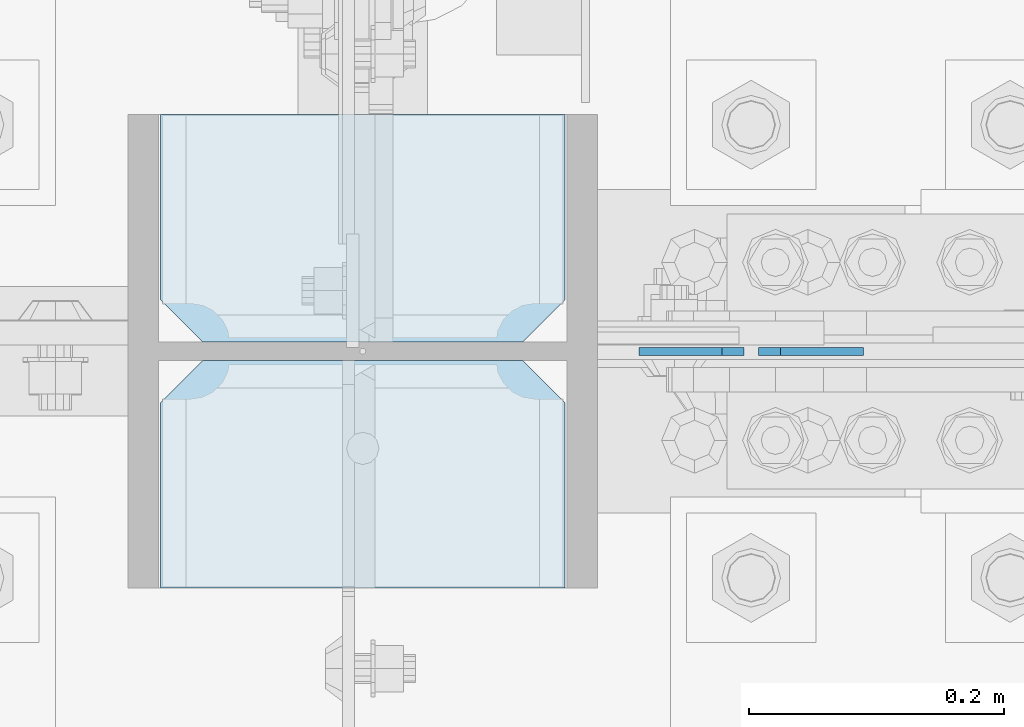
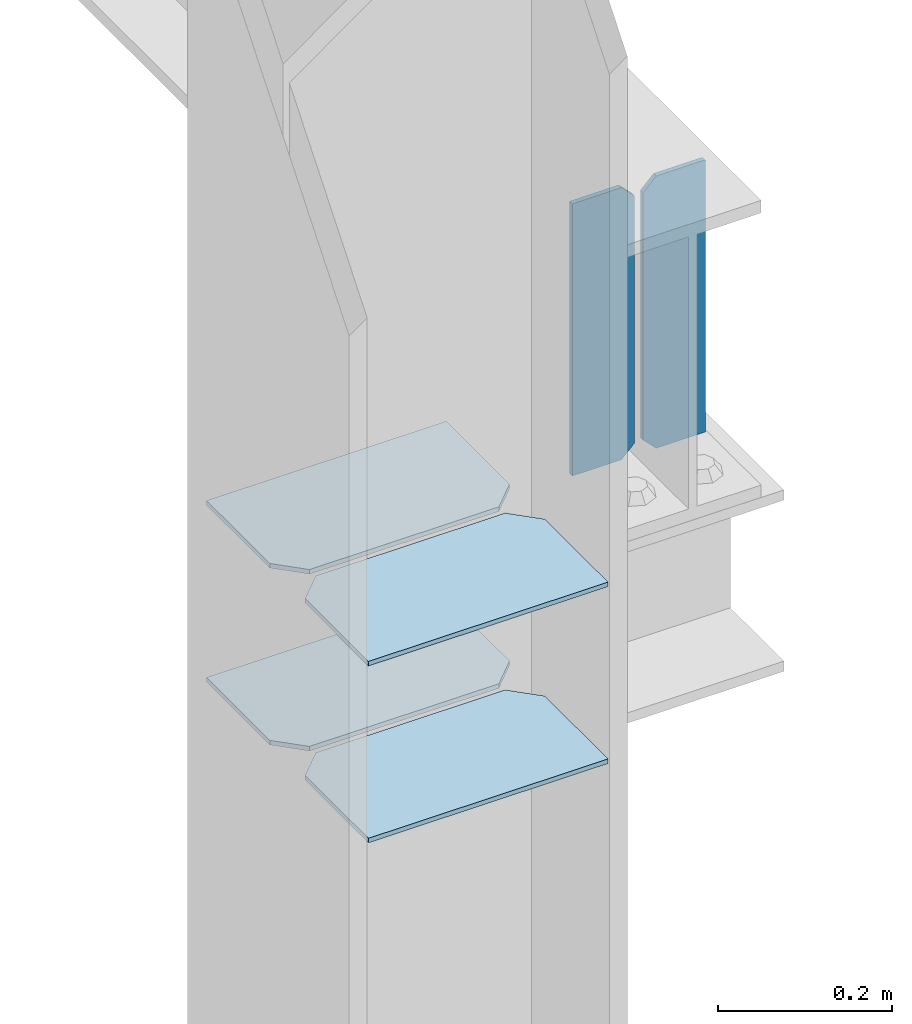
# One storey, part 3099 of 3843: 6 plates, 2 elements without a shape of their own.
"""IFC2X3 building model written with IfcOpenShell, lengths in millimetres."""

from ifc_helpers import new_model, si_unit, frame, origin_with_axes, place, context, subcontext, project, spatial, faceted_brep, material, type_object, element, aggregate, save


model = new_model("IFC2X3")

# Units and contexts
model_context = context("Model", 3, precision=1e-05, world=origin_with_axes())
body_context = subcontext(model_context, "Body", "Model", "MODEL_VIEW")
ifc_project = project(units=[si_unit("LENGTHUNIT", "METRE", prefix="MILLI"), si_unit("AREAUNIT", "SQUARE_METRE"), si_unit("VOLUMEUNIT", "CUBIC_METRE"), si_unit("MASSUNIT", "GRAM", prefix="KILO"), si_unit("TIMEUNIT", "SECOND"), si_unit("PLANEANGLEUNIT", "RADIAN"), si_unit("SOLIDANGLEUNIT", "STERADIAN"), si_unit("THERMODYNAMICTEMPERATUREUNIT", "DEGREE_CELSIUS"), si_unit("LUMINOUSINTENSITYUNIT", "LUMEN")], contexts=[model_context])

# Site, building, storey
site_placement = place(None, origin_with_axes())
site = spatial("IfcSite", under=ifc_project, at=site_placement, CompositionType="ELEMENT")
building_placement = place(site_placement, origin_with_axes())
building = spatial("IfcBuilding", under=site, at=building_placement, Name="Undefined", CompositionType="ELEMENT")
storey_placement = place(building_placement, origin_with_axes())
storey = spatial("IfcBuildingStorey", under=building, at=storey_placement, Name="Undefined", CompositionType="ELEMENT", Elevation=0.0)

# Assembly, plates
assembly_1_placement = place(storey_placement, origin_with_axes())
assembly_1 = element("IfcElementAssembly", 1, at=assembly_1_placement, inside=storey, Name="BEAM", AssemblyPlace="NOTDEFINED", PredefinedType="RIGID_FRAME")
ifc_material = material(Name="STEEL/A572-50")
plate_type_1 = type_object("IfcPlateType", PredefinedType="NOTDEFINED")
plate_1_placement = place(assembly_1_placement, frame((77405.70625, 14998.7, 39285.8625), z_axis=(0.0, 0.0, 1.0), x_axis=(-1.0, 0.0, 0.0)))
plate_1 = element("IfcPlate", 2, at=plate_1_placement, type_object=plate_type_1, material=ifc_material, Name="PLATE", context=body_context, shape_type="Brep", body=[
    faceted_brep([(0.0, -3.17499999999927, 0.0), (0.0, -3.17500000000291, 381.0), (0.0, 3.17500000000291, 381.0), (0.0, 3.17499999999927, 0.0), (65.0875034332275, -3.17500000000291, 381.0), (65.0875034332275, 3.17500000000291, 381.0), (82.5500030517578, -3.17500000000291, 363.53750038147), (82.5500030517578, 3.17500000000291, 363.53750038147), (82.5500030517578, -3.17500000000291, 17.4624996185303), (82.5500030517578, 3.17500000000291, 17.4624996185303), (65.0875034332275, -3.17500000000291, 0.0), (65.0875034332275, 3.17500000000291, 0.0)], [[[0, 1, 2, 3]], [[1, 4, 5, 2]], [[4, 6, 7, 5]], [[6, 8, 9, 7]], [[8, 10, 11, 9]], [[10, 0, 3, 11]], [[5, 7, 9, 11, 3, 2]], [[10, 8, 6, 4, 1, 0]]]),
])
plate_2_placement = place(assembly_1_placement, frame((77312.04375, 14998.7, 39285.8625), z_axis=(0.0, 0.0, 1.0), x_axis=(-1.0, 0.0, 0.0)))
plate_2 = element("IfcPlate", 3, at=plate_2_placement, type_object=plate_type_1, material=ifc_material, Name="PLATE", context=body_context, shape_type="Brep", body=[
    faceted_brep([(5.82076609134674e-11, -3.17499999999927, 17.4624996185667), (0.0, -3.17500000000291, 363.53750038147), (0.0, 3.17500000000291, 363.53750038147), (0.0, 3.17500000000655, 17.4624996185521), (17.4624996185303, -3.17500000000291, 381.0), (17.4624996185303, 3.17500000000291, 381.0), (82.5500030517578, -3.17500000000291, 381.0), (82.5500030517578, 3.17500000000291, 381.0), (82.5500007629398, -3.17500000000291, 0.0), (82.5500007629398, 3.17500000000291, 0.0), (17.4624996184866, -3.17500000000291, 7.27595761418343e-12), (17.462499618443, 3.17500000000291, -7.27595761418343e-12)], [[[0, 1, 2, 3]], [[1, 4, 5, 2]], [[4, 6, 7, 5]], [[6, 8, 9, 7]], [[8, 10, 11, 9]], [[10, 0, 3, 11]], [[5, 7, 9, 11, 3, 2]], [[10, 8, 6, 4, 1, 0]]]),
])
aggregate(assembly_1, [plate_1, plate_2])

assembly_2_placement = place(storey_placement, origin_with_axes())
assembly_2 = element("IfcElementAssembly", 4, at=assembly_2_placement, inside=storey, Name="COLUMN", AssemblyPlace="NOTDEFINED", PredefinedType="RIGID_FRAME")
plate_type_2 = type_object("IfcPlateType", PredefinedType="NOTDEFINED")
plate_3_placement = place(assembly_2_placement, frame((77171.55, 14812.9625, 39265.225), z_axis=(-1.0, 0.0, 0.0), x_axis=(0.0, 1.0, 0.0)))
plate_3 = element("IfcPlate", 5, at=plate_3_placement, type_object=plate_type_2, material=ifc_material, Name="PLATE", context=body_context, shape_type="Brep", body=[
    faceted_brep([(0.0, -3.17499999999927, 0.0), (0.0, -3.17500000000291, 317.5), (0.0, 3.17500000000291, 317.5), (0.0, 3.17499999999927, 0.0), (145.256248474121, -3.17500000000291, 317.5), (145.256248474121, 3.17500000000291, 317.5), (178.59375, -3.17500000000291, 284.162498474121), (178.59375, 3.17500000000291, 284.162498474121), (178.59375, -3.17500000000291, 33.3375015258789), (178.59375, 3.17500000000291, 33.3375015258789), (145.256248474121, -3.17500000000291, 0.0), (145.256248474121, 3.17500000000291, 0.0)], [[[0, 1, 2, 3]], [[1, 4, 5, 2]], [[4, 6, 7, 5]], [[6, 8, 9, 7]], [[8, 10, 11, 9]], [[10, 0, 3, 11]], [[5, 7, 9, 11, 3, 2]], [[10, 8, 6, 4, 1, 0]]]),
])
plate_4_placement = place(assembly_2_placement, frame((77171.55, 15005.84375, 39265.225), z_axis=(-1.0, 0.0, 0.0), x_axis=(0.0, 1.0, 0.0)))
plate_4 = element("IfcPlate", 6, at=plate_4_placement, type_object=plate_type_2, material=ifc_material, Name="PLATE", context=body_context, shape_type="Brep", body=[
    faceted_brep([(0.0, -3.17500000000291, 33.3375015258789), (0.0, -3.17500000000291, 284.162498474121), (0.0, 3.17500000000291, 284.162498474121), (0.0, 3.17500000000291, 33.3375015258789), (33.3375015258789, -3.17500000000291, 317.5), (33.3375015258789, 3.17500000000291, 317.5), (178.59375, -3.17500000000291, 317.5), (178.59375, 3.17500000000291, 317.5), (178.59375, -3.17500000000291, 0.0), (178.59375, 3.17500000000291, 0.0), (33.3375015258789, -3.17500000000291, 0.0), (33.3375015258789, 3.17500000000291, 0.0)], [[[0, 1, 2, 3]], [[1, 4, 5, 2]], [[4, 6, 7, 5]], [[6, 8, 9, 7]], [[8, 10, 11, 9]], [[10, 0, 3, 11]], [[5, 7, 9, 11, 3, 2]], [[10, 8, 6, 4, 1, 0]]]),
])
plate_5_placement = place(assembly_2_placement, frame((77171.55, 14812.9625, 39017.575), z_axis=(-1.0, 0.0, 0.0), x_axis=(0.0, 1.0, 0.0)))
plate_5 = element("IfcPlate", 7, at=plate_5_placement, type_object=plate_type_2, material=ifc_material, Name="PLATE", context=body_context, shape_type="Brep", body=[
    faceted_brep([(0.0, -3.17499999999927, 0.0), (0.0, -3.17500000000291, 317.5), (0.0, 3.17500000000291, 317.5), (0.0, 3.17499999999927, 0.0), (145.256248474121, -3.17500000000291, 317.5), (145.256248474121, 3.17500000000291, 317.5), (178.59375, -3.17500000000291, 284.162498474121), (178.59375, 3.17500000000291, 284.162498474121), (178.59375, -3.17500000000291, 33.3375015258789), (178.59375, 3.17500000000291, 33.3375015258789), (145.256248474121, -3.17500000000291, 0.0), (145.256248474121, 3.17500000000291, 0.0)], [[[0, 1, 2, 3]], [[1, 4, 5, 2]], [[4, 6, 7, 5]], [[6, 8, 9, 7]], [[8, 10, 11, 9]], [[10, 0, 3, 11]], [[5, 7, 9, 11, 3, 2]], [[10, 8, 6, 4, 1, 0]]]),
])
plate_6_placement = place(assembly_2_placement, frame((77171.55, 15005.84375, 39017.575), z_axis=(-1.0, 0.0, 0.0), x_axis=(0.0, 1.0, 0.0)))
plate_6 = element("IfcPlate", 8, at=plate_6_placement, type_object=plate_type_2, material=ifc_material, Name="PLATE", context=body_context, shape_type="Brep", body=[
    faceted_brep([(0.0, -3.17500000000291, 33.3375015258789), (0.0, -3.17500000000291, 284.162498474121), (0.0, 3.17500000000291, 284.162498474121), (0.0, 3.17500000000291, 33.3375015258789), (33.3375015258789, -3.17500000000291, 317.5), (33.3375015258789, 3.17500000000291, 317.5), (178.59375, -3.17500000000291, 317.5), (178.59375, 3.17500000000291, 317.5), (178.59375, -3.17500000000291, 0.0), (178.59375, 3.17500000000291, 0.0), (33.3375015258789, -3.17500000000291, 0.0), (33.3375015258789, 3.17500000000291, 0.0)], [[[0, 1, 2, 3]], [[1, 4, 5, 2]], [[4, 6, 7, 5]], [[6, 8, 9, 7]], [[8, 10, 11, 9]], [[10, 0, 3, 11]], [[5, 7, 9, 11, 3, 2]], [[10, 8, 6, 4, 1, 0]]]),
])
aggregate(assembly_2, [plate_3, plate_4, plate_5, plate_6])

save(model, "model.ifc")
